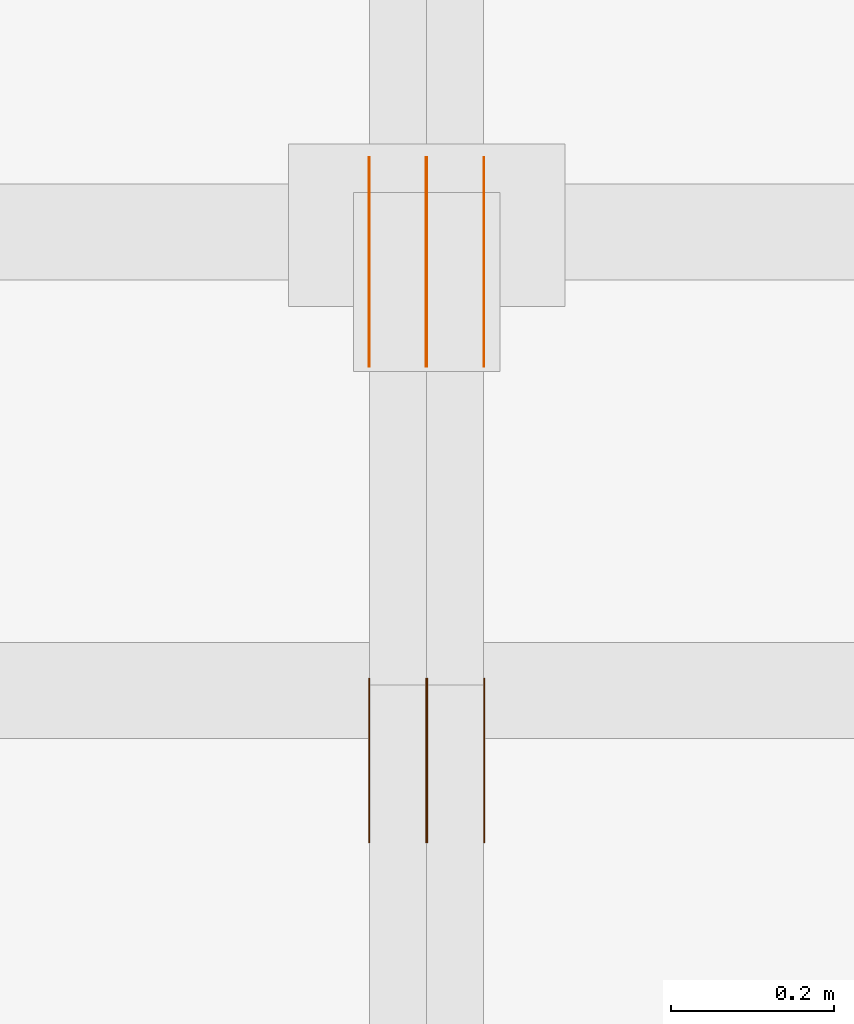
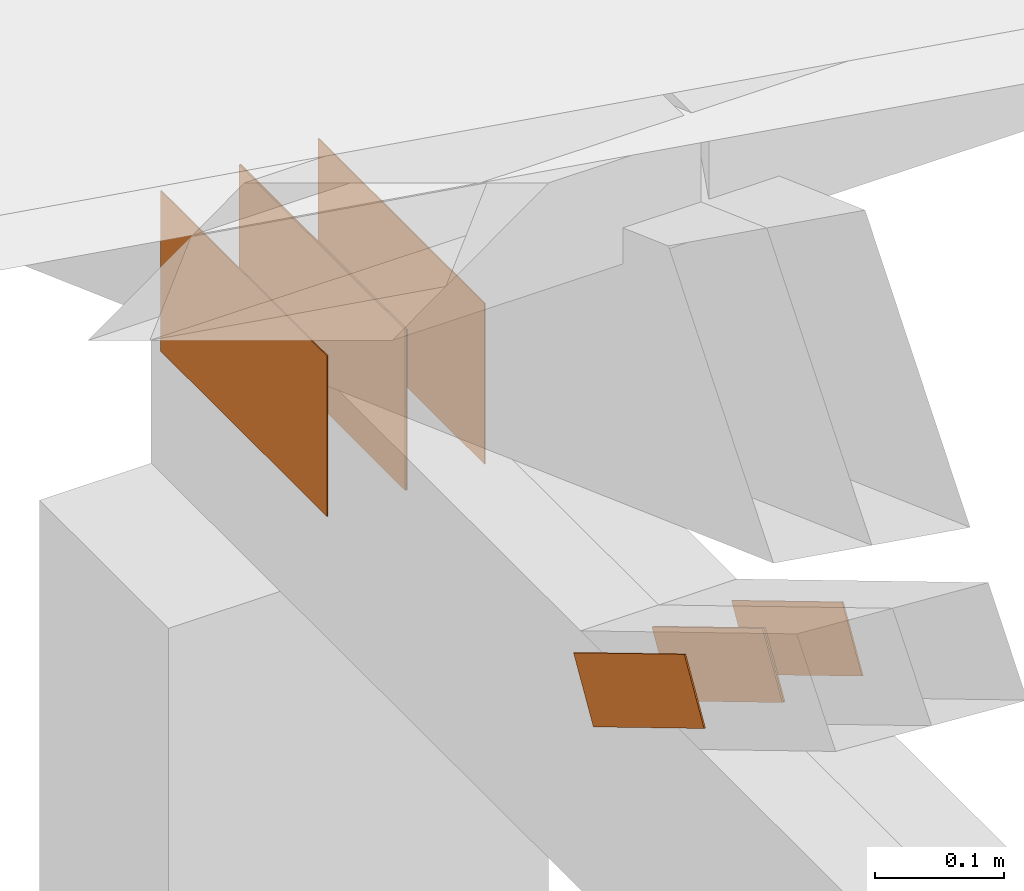
# One storey, part 135 of 189: 8 proxies.
"""IFC2X3 building model written with IfcOpenShell, lengths in millimetres."""

from ifc_helpers import new_model, entity, si_unit, converted_unit, derived_unit, direction, frame, origin, origin_2d_with_axis, place, context, subcontext, project, spatial, polyline, rectangle, outline, extrude, source, transform, mapped, material, type_object, type_shapes, element, save


model = new_model("IFC2X3")

# Units and contexts
model_context = context("Model", 3, precision=0.01, world=origin(), true_north=direction((6.12303176911189e-17, 1.0)))
body_context = subcontext(model_context, "Body", "Model", "MODEL_VIEW")
ifc_project = project(units=[si_unit("LENGTHUNIT", "METRE", prefix="MILLI"), si_unit("AREAUNIT", "SQUARE_METRE"), si_unit("VOLUMEUNIT", "CUBIC_METRE"), converted_unit("PLANEANGLEUNIT", "DEGREE", entity("IfcRatioMeasure", 0.0174532925199433), si_unit("PLANEANGLEUNIT", "RADIAN"), dimensions=[0, 0, 0, 0, 0, 0, 0]), si_unit("MASSUNIT", "GRAM", prefix="KILO"), derived_unit("MASSDENSITYUNIT", [(si_unit("MASSUNIT", "GRAM", prefix="KILO"), 1), (si_unit("LENGTHUNIT", "METRE"), -3)]), si_unit("TIMEUNIT", "SECOND"), si_unit("FREQUENCYUNIT", "HERTZ"), si_unit("THERMODYNAMICTEMPERATUREUNIT", "DEGREE_CELSIUS"), derived_unit("THERMALTRANSMITTANCEUNIT", [(si_unit("MASSUNIT", "GRAM", prefix="KILO"), 1), (si_unit("THERMODYNAMICTEMPERATUREUNIT", "KELVIN"), -1), (si_unit("TIMEUNIT", "SECOND"), -3)]), derived_unit("VOLUMETRICFLOWRATEUNIT", [(si_unit("LENGTHUNIT", "METRE"), 3), (si_unit("TIMEUNIT", "SECOND"), -1)]), si_unit("ELECTRICCURRENTUNIT", "AMPERE"), si_unit("ELECTRICVOLTAGEUNIT", "VOLT"), si_unit("POWERUNIT", "WATT"), si_unit("FORCEUNIT", "NEWTON"), si_unit("ILLUMINANCEUNIT", "LUX"), si_unit("LUMINOUSFLUXUNIT", "LUMEN"), si_unit("LUMINOUSINTENSITYUNIT", "CANDELA"), derived_unit("USERDEFINED", [(si_unit("MASSUNIT", "GRAM", prefix="KILO"), -1), (si_unit("LENGTHUNIT", "METRE"), -2), (si_unit("TIMEUNIT", "SECOND"), 3), (si_unit("LUMINOUSFLUXUNIT", "LUMEN"), 1)]), derived_unit("LINEARVELOCITYUNIT", [(si_unit("LENGTHUNIT", "METRE"), 1), (si_unit("TIMEUNIT", "SECOND"), -1)]), si_unit("PRESSUREUNIT", "PASCAL"), derived_unit("USERDEFINED", [(si_unit("LENGTHUNIT", "METRE"), -2), (si_unit("MASSUNIT", "GRAM", prefix="KILO"), 1), (si_unit("TIMEUNIT", "SECOND"), -2)])], contexts=[model_context])

# Site, building, storey
site_placement = place(None, origin())
site = spatial("IfcSite", under=ifc_project, at=site_placement, CompositionType="ELEMENT")
building_placement = place(site_placement, origin())
building = spatial("IfcBuilding", under=site, at=building_placement, CompositionType="ELEMENT")
storey_placement = place(building_placement, origin())
storey = spatial("IfcBuildingStorey", under=building, at=storey_placement, Name="Default", CompositionType="ELEMENT", Elevation=0.0)

# Proxies
ifc_material_1 = material(Name="IfcSurfaceStyle #166674")
building_element_proxy_type_1 = type_object("IfcBuildingElementProxyType", PredefinedType="NOTDEFINED", material=ifc_material_1)
shared_shape_1 = source(origin(), body_context, "Body", "SweptSolid", [
    extrude(outline(polyline([(-100.000014621824, -30.0000173081658), (100.000025679578, -30.0000173081658), (100.000010707989, 30.0000173081658), (-100.000021765743, 30.0000173081658), (-100.000014621824, -30.0000173081658)])), frame((100.000025679578, 30.0000173081658, 0.0), z_axis=(0.0, 0.0, 1.0), x_axis=(-1.0, 0.0, 0.0)), (0.0, 0.0, 1.0), 1.3),
])
type_shapes(building_element_proxy_type_1, [shared_shape_1])
proxy_1_placement = place(building_placement, frame((30301.3, 28812.2744732883, 167.948789809131), z_axis=(-1.0, 0.0, 0.0), x_axis=(0.0, -0.858392121304013, 0.51299411895576)))
element("IfcBuildingElementProxy", 1, at=proxy_1_placement, inside=storey, type_object=building_element_proxy_type_1, material=ifc_material_1, context=body_context, shape_type="MappedRepresentation", body=[
    mapped(shared_shape_1, transform((0.0, 0.0, 0.0), scale=1.0)),
])
ifc_material_2 = material(Name="IfcSurfaceStyle #166617")
building_element_proxy_type_2 = type_object("IfcBuildingElementProxyType", PredefinedType="NOTDEFINED", material=ifc_material_2)
shared_shape_2 = source(origin(), body_context, "Body", "SweptSolid", [
    extrude(outline(polyline([(-100.000014621824, -30.0000173081658), (100.000025679578, -30.0000173081658), (100.000010707989, 30.0000173081658), (-100.000021765743, 30.0000173081658), (-100.000014621824, -30.0000173081658)])), frame((100.000025679578, 30.0000173081658, 0.0), z_axis=(0.0, 0.0, 1.0), x_axis=(-1.0, 0.0, 0.0)), (0.0, 0.0, 1.0), 1.29999999999998),
])
type_shapes(building_element_proxy_type_2, [shared_shape_2])
proxy_2_placement = place(building_placement, frame((30230.0, 28812.2744732883, 167.948789809131), z_axis=(-1.0, 0.0, 0.0), x_axis=(0.0, -0.858392121304013, 0.51299411895576)))
element("IfcBuildingElementProxy", 2, at=proxy_2_placement, inside=storey, type_object=building_element_proxy_type_2, material=ifc_material_2, context=body_context, shape_type="MappedRepresentation", body=[
    mapped(shared_shape_2, transform((0.0, 0.0, 0.0), scale=1.0)),
])
ifc_material_3 = material(Name="IfcSurfaceStyle #166560")
building_element_proxy_type_3 = type_object("IfcBuildingElementProxyType", PredefinedType="NOTDEFINED", material=ifc_material_3)
shared_shape_3 = source(origin(), body_context, "Body", "SweptSolid", [
    extrude(outline(polyline([(-100.000014621824, -30.0000173081658), (100.000025679578, -30.0000173081658), (100.000010707989, 30.0000173081658), (-100.000021765743, 30.0000173081658), (-100.000014621824, -30.0000173081658)])), frame((100.000025679578, 30.0000173081658, 0.0), z_axis=(0.0, 0.0, 1.0), x_axis=(-1.0, 0.0, 0.0)), (0.0, 0.0, 1.0), 1.29999999999998),
])
type_shapes(building_element_proxy_type_3, [shared_shape_3])
proxy_3_placement = place(building_placement, frame((30231.3, 28812.2744732883, 167.948789809131), z_axis=(-1.0, 0.0, 0.0), x_axis=(0.0, -0.858392121304013, 0.51299411895576)))
element("IfcBuildingElementProxy", 3, at=proxy_3_placement, inside=storey, type_object=building_element_proxy_type_3, material=ifc_material_3, context=body_context, shape_type="MappedRepresentation", body=[
    mapped(shared_shape_3, transform((0.0, 0.0, 0.0), scale=1.0)),
])
ifc_material_4 = material(Name="IfcSurfaceStyle #166503")
building_element_proxy_type_4 = type_object("IfcBuildingElementProxyType", PredefinedType="NOTDEFINED", material=ifc_material_4)
shared_shape_4 = source(origin(), body_context, "Body", "SweptSolid", [
    extrude(outline(polyline([(-100.000014621824, -30.0000173081658), (100.000025679578, -30.0000173081658), (100.000010707989, 30.0000173081658), (-100.000021765743, 30.0000173081658), (-100.000014621824, -30.0000173081658)])), frame((100.000025679578, 30.0000173081658, 0.0), z_axis=(0.0, 0.0, 1.0), x_axis=(-1.0, 0.0, 0.0)), (0.0, 0.0, 1.0), 1.29999999999999),
])
type_shapes(building_element_proxy_type_4, [shared_shape_4])
proxy_4_placement = place(building_placement, frame((30160.0, 28812.2744732883, 167.948789809131), z_axis=(-1.0, 0.0, 0.0), x_axis=(0.0, -0.858392121304013, 0.51299411895576)))
element("IfcBuildingElementProxy", 4, at=proxy_4_placement, inside=storey, type_object=building_element_proxy_type_4, material=ifc_material_4, context=body_context, shape_type="MappedRepresentation", body=[
    mapped(shared_shape_4, transform((0.0, 0.0, 0.0), scale=1.0)),
])
ifc_material_5 = material(Name="IfcSurfaceStyle #166218")
building_element_proxy_type_5 = type_object("IfcBuildingElementProxyType", PredefinedType="NOTDEFINED", material=ifc_material_5)
shared_shape_5 = source(origin(), body_context, "Body", "SweptSolid", [
    extrude(rectangle(XDim=258.000001907349, YDim=151.999992370605, at=origin_2d_with_axis()), frame((129.000001782157, 75.9999961853027, 0.0), z_axis=(0.0, 0.0, 1.0), x_axis=(-1.0, 0.0, 0.0)), (0.0, 0.0, 1.0), 0.999999999999984),
])
type_shapes(building_element_proxy_type_5, [shared_shape_5])
proxy_5_placement = place(building_placement, frame((30301.0, 29483.7634609878, 116.138221740723), z_axis=(-1.0, 0.0, 0.0), x_axis=(0.0, -1.0, 0.0)))
element("IfcBuildingElementProxy", 5, at=proxy_5_placement, inside=storey, type_object=building_element_proxy_type_5, material=ifc_material_5, Name="GNT100S 152x258", context=body_context, shape_type="MappedRepresentation", body=[
    mapped(shared_shape_5, transform((0.0, 0.0, 0.0), scale=1.0)),
])
ifc_material_6 = material(Name="IfcSurfaceStyle #166161")
building_element_proxy_type_6 = type_object("IfcBuildingElementProxyType", PredefinedType="NOTDEFINED", material=ifc_material_6)
shared_shape_6 = source(origin(), body_context, "Body", "SweptSolid", [
    extrude(rectangle(XDim=258.000001907349, YDim=151.999992370605, at=origin_2d_with_axis()), frame((129.000001782157, 75.9999961853027, 0.0), z_axis=(0.0, 0.0, 1.0), x_axis=(-1.0, 0.0, 0.0)), (0.0, 0.0, 1.0), 0.999999999999984),
])
type_shapes(building_element_proxy_type_6, [shared_shape_6])
proxy_6_placement = place(building_placement, frame((30230.0, 29483.7634609878, 116.138221740723), z_axis=(-1.0, 0.0, 0.0), x_axis=(0.0, -1.0, 0.0)))
element("IfcBuildingElementProxy", 6, at=proxy_6_placement, inside=storey, type_object=building_element_proxy_type_6, material=ifc_material_6, Name="GNT100S 152x258", context=body_context, shape_type="MappedRepresentation", body=[
    mapped(shared_shape_6, transform((0.0, 0.0, 0.0), scale=1.0)),
])
ifc_material_7 = material(Name="IfcSurfaceStyle #166104")
building_element_proxy_type_7 = type_object("IfcBuildingElementProxyType", PredefinedType="NOTDEFINED", material=ifc_material_7)
shared_shape_7 = source(origin(), body_context, "Body", "SweptSolid", [
    extrude(rectangle(XDim=258.000001907349, YDim=151.999992370605, at=origin_2d_with_axis()), frame((129.000001782157, 75.9999961853027, 0.0), z_axis=(0.0, 0.0, 1.0), x_axis=(-1.0, 0.0, 0.0)), (0.0, 0.0, 1.0), 0.999999999999984),
])
type_shapes(building_element_proxy_type_7, [shared_shape_7])
proxy_7_placement = place(building_placement, frame((30231.0, 29483.7634609878, 116.138221740723), z_axis=(-1.0, 0.0, 0.0), x_axis=(0.0, -1.0, 0.0)))
element("IfcBuildingElementProxy", 7, at=proxy_7_placement, inside=storey, type_object=building_element_proxy_type_7, material=ifc_material_7, Name="GNT100S 152x258", context=body_context, shape_type="MappedRepresentation", body=[
    mapped(shared_shape_7, transform((0.0, 0.0, 0.0), scale=1.0)),
])
ifc_material_8 = material(Name="IfcSurfaceStyle #166047")
building_element_proxy_type_8 = type_object("IfcBuildingElementProxyType", PredefinedType="NOTDEFINED", material=ifc_material_8)
shared_shape_8 = source(origin(), body_context, "Body", "SweptSolid", [
    extrude(rectangle(XDim=258.000001907349, YDim=151.999992370605, at=origin_2d_with_axis()), frame((129.000001782157, 75.9999961853027, 0.0), z_axis=(0.0, 0.0, 1.0), x_axis=(-1.0, 0.0, 0.0)), (0.0, 0.0, 1.0), 0.999999999999984),
])
type_shapes(building_element_proxy_type_8, [shared_shape_8])
proxy_8_placement = place(building_placement, frame((30160.0, 29483.7634609878, 116.138221740723), z_axis=(-1.0, 0.0, 0.0), x_axis=(0.0, -1.0, 0.0)))
element("IfcBuildingElementProxy", 8, at=proxy_8_placement, inside=storey, type_object=building_element_proxy_type_8, material=ifc_material_8, Name="GNT100S 152x258", context=body_context, shape_type="MappedRepresentation", body=[
    mapped(shared_shape_8, transform((0.0, 0.0, 0.0), scale=1.0)),
])

save(model, "model.ifc")
